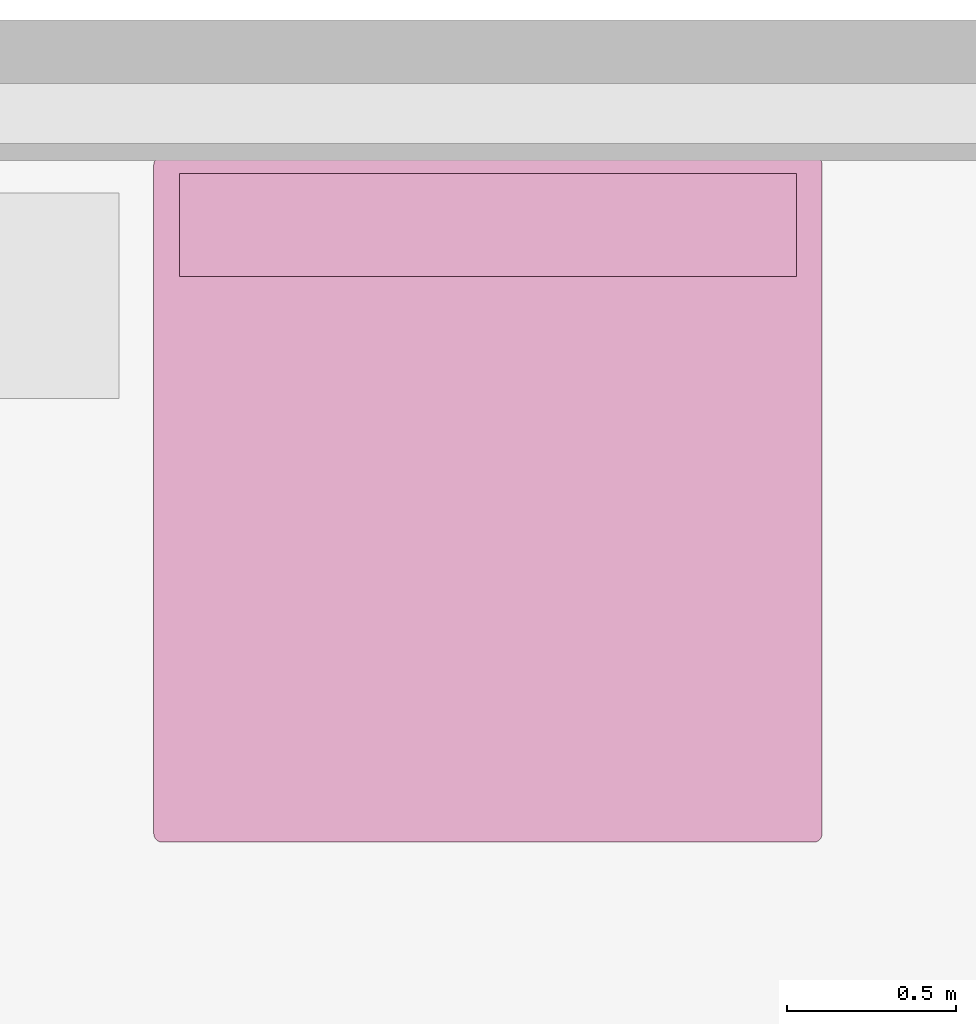
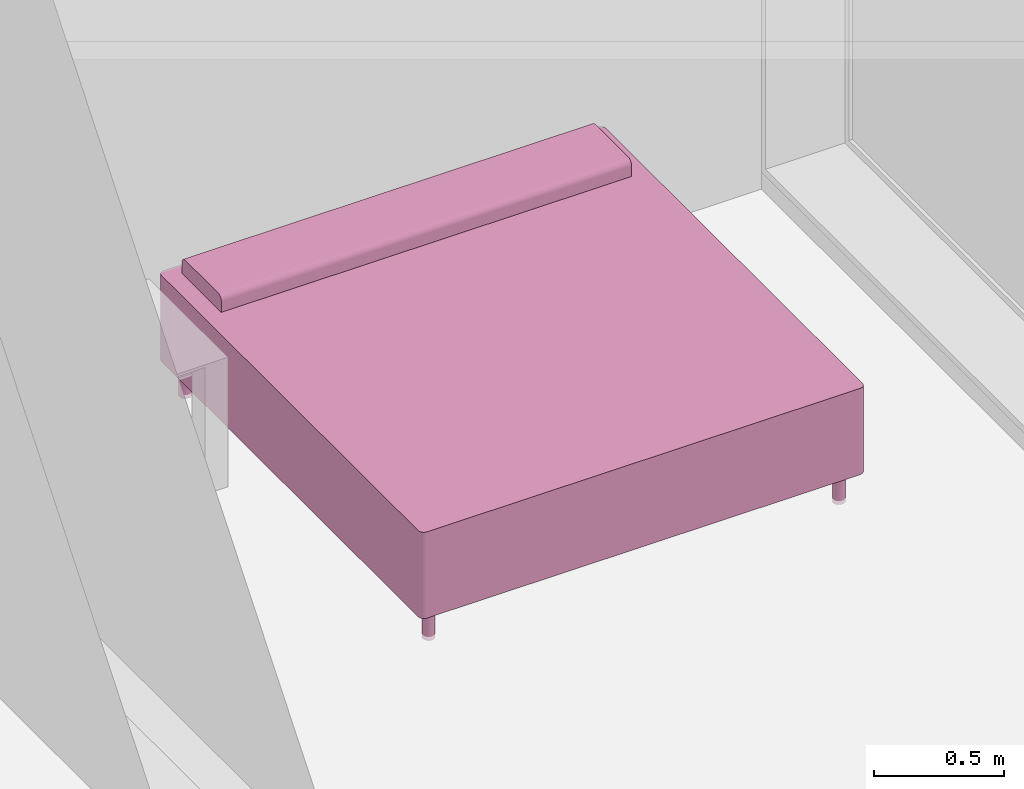
# One storey, part 10 of 10: 1 furnishing.
"""IFC2X3 building model written with IfcOpenShell, lengths in metres."""

from ifc_helpers import new_model, entity, si_unit, converted_unit, derived_unit, direction, frame, frame_2d, origin, place, context, subcontext, project, spatial, polyline, circle_curve, parameter, trimmed, segment, composite_curve, circle, outline, extrude, source, transform, mapped, material, material_list, type_object, type_shapes, element, save


model = new_model("IFC2X3")

# Units and contexts
model_context = context("Model", 3, precision=1e-05, world=origin(), true_north=direction((6.12303176911189e-17, 1.0)))
body_context = subcontext(model_context, "Body", "Model", "MODEL_VIEW")
ifc_project = project(units=[derived_unit("USERDEFINED", [(si_unit("LENGTHUNIT", "METRE"), -2), (si_unit("TIMEUNIT", "SECOND"), -2), (si_unit("MASSUNIT", "GRAM", prefix="KILO"), 1)]), si_unit("FREQUENCYUNIT", "HERTZ"), si_unit("LENGTHUNIT", "METRE"), si_unit("ILLUMINANCEUNIT", "LUX"), derived_unit("LINEARVELOCITYUNIT", [(si_unit("TIMEUNIT", "SECOND"), -1), (si_unit("LENGTHUNIT", "METRE"), 1)]), si_unit("POWERUNIT", "WATT"), si_unit("LUMINOUSINTENSITYUNIT", "CANDELA"), si_unit("AREAUNIT", "SQUARE_METRE"), si_unit("VOLUMEUNIT", "CUBIC_METRE"), si_unit("ELECTRICVOLTAGEUNIT", "VOLT"), si_unit("PRESSUREUNIT", "PASCAL"), converted_unit("PLANEANGLEUNIT", "DEGREE", entity("IfcRatioMeasure", 0.0174532925199433), si_unit("PLANEANGLEUNIT", "RADIAN"), dimensions=[0, 0, 0, 0, 0, 0, 0]), si_unit("THERMODYNAMICTEMPERATUREUNIT", "DEGREE_CELSIUS"), si_unit("MASSUNIT", "GRAM", prefix="KILO"), derived_unit("VOLUMETRICFLOWRATEUNIT", [(si_unit("LENGTHUNIT", "METRE"), 3), (si_unit("TIMEUNIT", "SECOND"), -1)]), si_unit("TIMEUNIT", "SECOND"), si_unit("LUMINOUSFLUXUNIT", "LUMEN"), derived_unit("USERDEFINED", [(si_unit("LUMINOUSFLUXUNIT", "LUMEN"), 1), (si_unit("TIMEUNIT", "SECOND"), 3), (si_unit("MASSUNIT", "GRAM", prefix="KILO"), -1), (si_unit("LENGTHUNIT", "METRE"), -2)]), si_unit("FORCEUNIT", "NEWTON", prefix="KILO"), si_unit("ELECTRICCURRENTUNIT", "AMPERE"), derived_unit("THERMALTRANSMITTANCEUNIT", [(si_unit("TIMEUNIT", "SECOND"), -3), (si_unit("THERMODYNAMICTEMPERATUREUNIT", "KELVIN"), -1), (si_unit("MASSUNIT", "GRAM", prefix="KILO"), 1)])], contexts=[model_context])

# Site, building, storey, space
site_placement = place(None, origin())
site = spatial("IfcSite", under=ifc_project, at=site_placement, CompositionType="ELEMENT")
building_placement = place(site_placement, origin())
building = spatial("IfcBuilding", under=site, at=building_placement, CompositionType="ELEMENT")
storey_placement = place(building_placement, frame((0.0, 0.0, 3.10000000000038)))
storey = spatial("IfcBuildingStorey", under=building, at=storey_placement, Name="Level 2", CompositionType="ELEMENT", Elevation=3.10000000000038)
space_placement = place(storey_placement, origin())
space = spatial("IfcSpace", under=storey, at=space_placement, CompositionType="ELEMENT", InteriorOrExteriorSpace="INTERNAL")

# Furnishing
ifc_material_1 = material(Name="Textile - White")
ifc_material_2 = material(Name="Metal - Chrome")
ifc_material_list_1 = material_list([ifc_material_1, ifc_material_2])
ifc_material_list_2 = material_list([ifc_material_1, ifc_material_2])
furniture_type = type_object("IfcFurnitureType", Name="1981 x 2032mm - King", AssemblyPlace="NOTDEFINED", material=ifc_material_list_2)
shared_shape = source(origin(), body_context, "Body", "SweptSolid", [
    extrude(outline(composite_curve([segment(polyline([(-0.1524, -0.0423333333333332), (0.1524, -0.0423333333333332)]), True, "CONTINUOUS"), segment(polyline([(0.1524, -0.0423333333333332), (0.1524, 0.00846666666666662)]), True, "CONTINUOUS"), segment(trimmed(circle_curve(frame_2d((0.127, 0.00846666666666662), x_axis=(-1.0, 0.0)), 0.0254), [parameter(180.0)], [parameter(270.0)], True, "PARAMETER"), True, "CONTINUOUS"), segment(polyline([(0.127, 0.0338666666666666), (-0.127, 0.0338666666666666)]), True, "CONTINUOUS"), segment(trimmed(circle_curve(frame_2d((-0.127, 0.00846666666666673), x_axis=(-1.0, 0.0)), 0.0254), [parameter(270.0)], [parameter(0.0)], True, "PARAMETER"), True, "CONTINUOUS"), segment(polyline([(-0.1524, 0.00846666666666673), (-0.1524, -0.0423333333333332)]), True, "CONTINUOUS")], self_intersect=False)), frame((-0.642811475409803, 0.767204918032816, 0.601133333333333), z_axis=(1.0, 0.0, 0.0), x_axis=(0.0, 1.0, 0.0)), (0.0, 0.0, 1.0), 1.82859999999997),
    extrude(circle(Radius=0.0254000000000034, at=frame_2d((0.0, -1.35358391162299e-16), x_axis=(1.0, 0.0))), frame((-0.642811475409802, -0.985395081967205, 0.0)), (0.0, 0.0, 1.0), 0.1524),
    extrude(outline(composite_curve([segment(trimmed(circle_curve(frame_2d((-0.965099999999988, -0.990600000000012), x_axis=(1.0, 0.0)), 0.0254000000000003), [parameter(180.0)], [parameter(270.0)], True, "PARAMETER"), True, "CONTINUOUS"), segment(polyline([(-0.965099999999988, -1.01600000000001), (0.965100000000011, -1.01600000000001)]), True, "CONTINUOUS"), segment(trimmed(circle_curve(frame_2d((0.965100000000011, -0.990600000000044), x_axis=(1.0, 0.0)), 0.0253999999999749), [parameter(270.0)], [parameter(360.0)], True, "PARAMETER"), True, "CONTINUOUS"), segment(polyline([(0.990499999999986, -0.990600000000044), (0.99049999999998, 0.990600000000046)]), True, "CONTINUOUS"), segment(trimmed(circle_curve(frame_2d((0.965100000000038, 0.990600000000046), x_axis=(1.0, 0.0)), 0.0253999999999504), [parameter(3.05333249420498e-13)], [parameter(89.9999999999995)], True, "PARAMETER"), True, "CONTINUOUS"), segment(polyline([(0.965100000000038, 1.016), (-0.965100000000049, 1.01599999999999)]), True, "CONTINUOUS"), segment(trimmed(circle_curve(frame_2d((-0.965100000000049, 0.990600000000048), x_axis=(1.0, 0.0)), 0.0253999999999488), [parameter(90.0000000000001)], [parameter(180.0)], True, "PARAMETER"), True, "CONTINUOUS"), segment(polyline([(-0.990499999999998, 0.990600000000048), (-0.990499999999989, -0.990600000000012)]), True, "CONTINUOUS")], self_intersect=False)), frame((0.271488524590187, -0.0455950819671894, 0.1524)), (0.0, 0.0, 1.0), 0.2032),
    extrude(circle(Radius=0.0254, at=frame_2d((0.0, -1.35358391162299e-16), x_axis=(1.0, 0.0))), frame((1.18578852459019, -0.985395081967167, 0.0)), (0.0, 0.0, 1.0), 0.1524),
    extrude(circle(Radius=0.0254000000000244, at=frame_2d((-1.35358391162299e-16, -1.35358391162299e-16), x_axis=(1.0, 0.0))), frame((1.18578852459016, 0.894204918032828, 0.0)), (0.0, 0.0, 1.0), 0.1524),
    extrude(circle(Radius=0.0253999999999999, at=frame_2d((0.0, -1.35358391162299e-16), x_axis=(1.0, 0.0))), frame((-0.642811475409827, 0.894204918032794, 0.0)), (0.0, 0.0, 1.0), 0.1524),
    extrude(outline(composite_curve([segment(trimmed(circle_curve(frame_2d((-0.965100000000049, 0.990600000000047), x_axis=(1.0, 0.0)), 0.0253999999999498), [parameter(90.0000000000001)], [parameter(180.0)], True, "PARAMETER"), True, "CONTINUOUS"), segment(polyline([(-0.990499999999999, 0.990600000000047), (-0.990499999999989, -0.990600000000012)]), True, "CONTINUOUS"), segment(trimmed(circle_curve(frame_2d((-0.965099999999988, -0.990600000000011), x_axis=(1.0, 0.0)), 0.0254000000000007), [parameter(180.0)], [parameter(270.0)], True, "PARAMETER"), True, "CONTINUOUS"), segment(polyline([(-0.965099999999989, -1.01600000000001), (0.965100000000011, -1.01600000000001)]), True, "CONTINUOUS"), segment(trimmed(circle_curve(frame_2d((0.965100000000011, -0.990600000000044), x_axis=(1.0, 0.0)), 0.0253999999999751), [parameter(269.999999999999)], [parameter(360.0)], True, "PARAMETER"), True, "CONTINUOUS"), segment(polyline([(0.990499999999986, -0.990600000000044), (0.99049999999998, 0.990600000000047)]), True, "CONTINUOUS"), segment(trimmed(circle_curve(frame_2d((0.965100000000039, 0.990600000000047), x_axis=(1.0, 0.0)), 0.0253999999999497), [parameter(360.0)], [parameter(89.9999999999995)], True, "PARAMETER"), True, "CONTINUOUS"), segment(polyline([(0.965100000000039, 1.016), (-0.965100000000049, 1.01599999999999)]), True, "CONTINUOUS")], self_intersect=False)), frame((0.271488524590187, -0.0455950819671895, 0.3556)), (0.0, 0.0, 1.0), 0.2032),
])
type_shapes(furniture_type, [shared_shape])
furnishing_placement = place(space_placement, frame((6.42101147540983, -1.3749049180328, 0.0)))
element("IfcFurnishingElement", 1, at=furnishing_placement, inside=space, type_object=furniture_type, material=ifc_material_list_1, Name="M_Bed-Standard:1981 x 2032mm - King", ObjectType="1981 x 2032mm - King", context=body_context, shape_type="MappedRepresentation", body=[
    mapped(shared_shape, transform((0.0, 0.0, 0.0), scale=1.0)),
])

save(model, "model.ifc")
